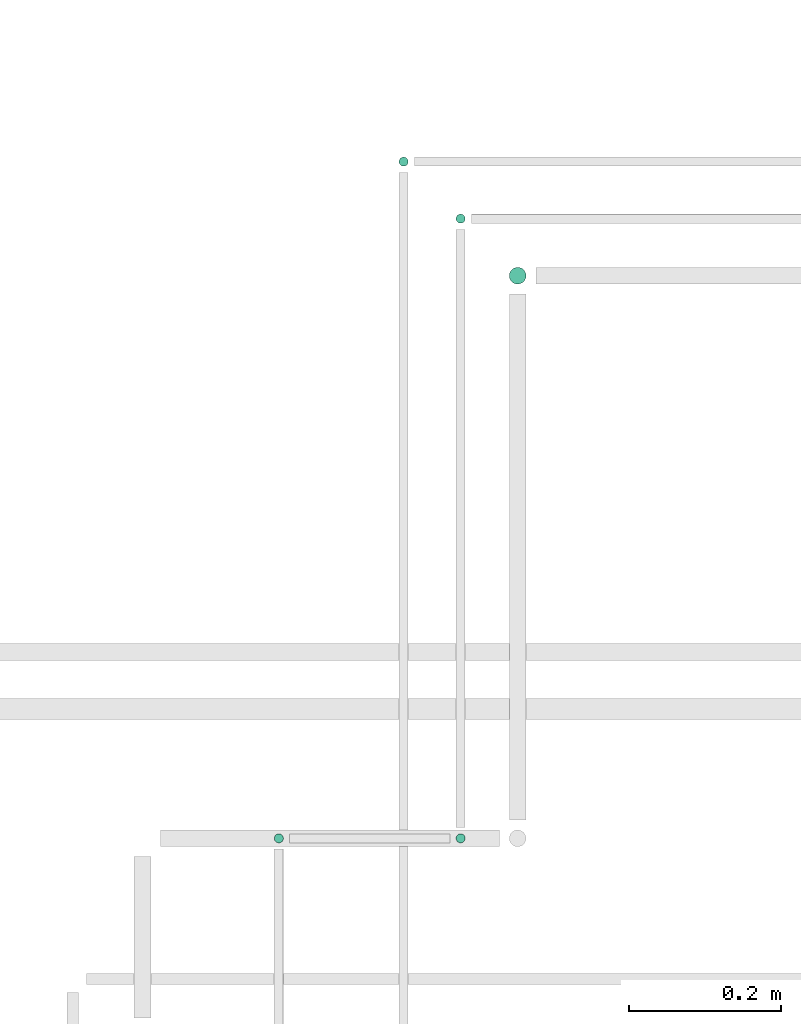
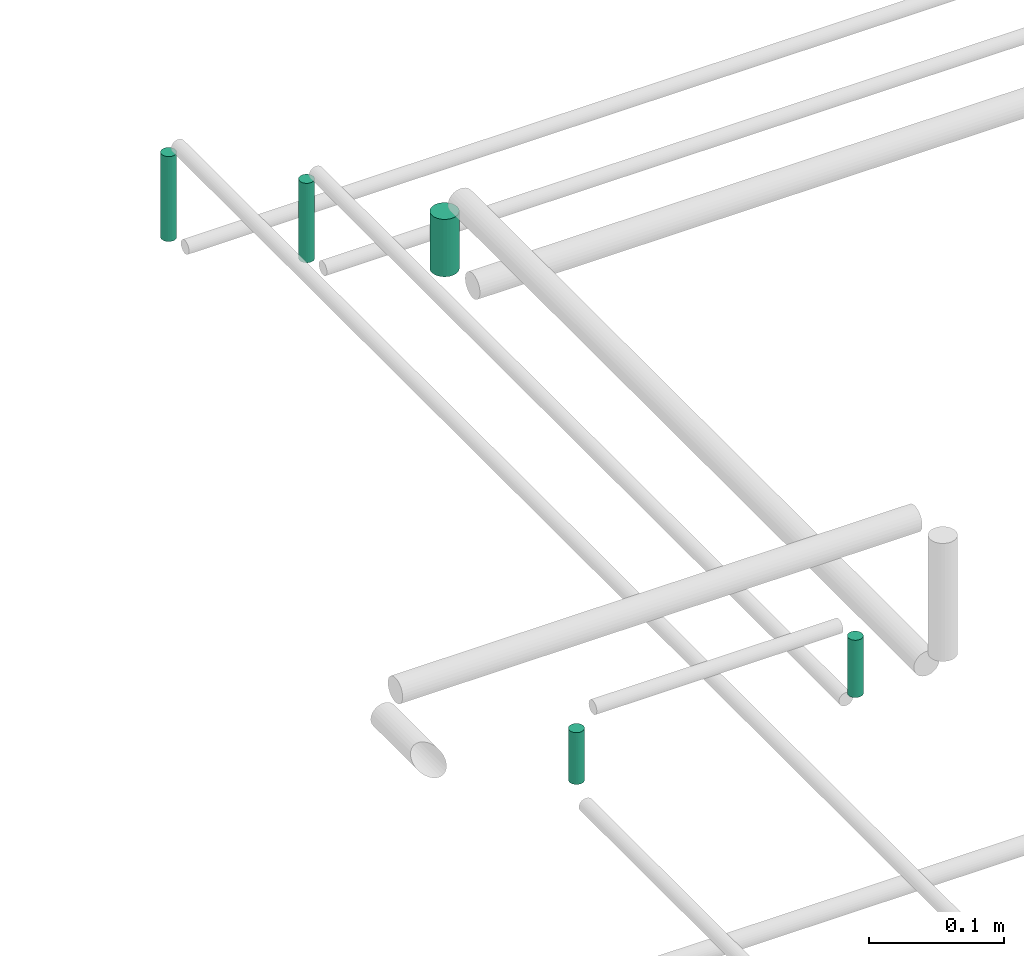
# One storey, part 251 of 331: 5 flow segments.
"""IFC2X3 building model written with IfcOpenShell, lengths in millimetres."""

from ifc_helpers import new_model, entity, si_unit, converted_unit, derived_unit, direction, frame, origin, origin_2d_with_axis, place, context, subcontext, project, spatial, circle, extrude, type_object, element, save


model = new_model("IFC2X3")

# Units and contexts
model_context = context("Model", 3, precision=0.01, world=origin(), true_north=direction((6.12303176911189e-17, 1.0)))
body_context = subcontext(model_context, "Body", "Model", "MODEL_VIEW")
ifc_project = project(units=[si_unit("LENGTHUNIT", "METRE", prefix="MILLI"), si_unit("AREAUNIT", "SQUARE_METRE"), si_unit("VOLUMEUNIT", "CUBIC_METRE"), converted_unit("PLANEANGLEUNIT", "DEGREE", entity("IfcRatioMeasure", 0.0174532925199433), si_unit("PLANEANGLEUNIT", "RADIAN"), dimensions=[0, 0, 0, 0, 0, 0, 0]), si_unit("MASSUNIT", "GRAM", prefix="KILO"), derived_unit("MASSDENSITYUNIT", [(si_unit("MASSUNIT", "GRAM", prefix="KILO"), 1), (si_unit("LENGTHUNIT", "METRE"), -3)]), derived_unit("MOMENTOFINERTIAUNIT", [(si_unit("LENGTHUNIT", "METRE"), 4)]), si_unit("TIMEUNIT", "SECOND"), si_unit("FREQUENCYUNIT", "HERTZ"), si_unit("THERMODYNAMICTEMPERATUREUNIT", "DEGREE_CELSIUS"), derived_unit("THERMALTRANSMITTANCEUNIT", [(si_unit("MASSUNIT", "GRAM", prefix="KILO"), 1), (si_unit("THERMODYNAMICTEMPERATUREUNIT", "KELVIN"), -1), (si_unit("TIMEUNIT", "SECOND"), -3)]), derived_unit("VOLUMETRICFLOWRATEUNIT", [(si_unit("LENGTHUNIT", "METRE"), 3), (si_unit("TIMEUNIT", "SECOND"), -1)]), derived_unit("MASSFLOWRATEUNIT", [(si_unit("MASSUNIT", "GRAM", prefix="KILO"), 1), (si_unit("TIMEUNIT", "SECOND"), -1)]), derived_unit("ROTATIONALFREQUENCYUNIT", [(si_unit("TIMEUNIT", "SECOND"), -1)]), si_unit("ELECTRICCURRENTUNIT", "AMPERE"), si_unit("ELECTRICVOLTAGEUNIT", "VOLT"), si_unit("POWERUNIT", "WATT"), si_unit("FORCEUNIT", "NEWTON", prefix="KILO"), si_unit("ILLUMINANCEUNIT", "LUX"), si_unit("LUMINOUSFLUXUNIT", "LUMEN"), si_unit("LUMINOUSINTENSITYUNIT", "CANDELA"), derived_unit("USERDEFINED", [(si_unit("MASSUNIT", "GRAM", prefix="KILO"), -1), (si_unit("LENGTHUNIT", "METRE"), -2), (si_unit("TIMEUNIT", "SECOND"), 3), (si_unit("LUMINOUSFLUXUNIT", "LUMEN"), 1)]), derived_unit("LINEARVELOCITYUNIT", [(si_unit("LENGTHUNIT", "METRE"), 1), (si_unit("TIMEUNIT", "SECOND"), -1)]), si_unit("PRESSUREUNIT", "PASCAL"), derived_unit("USERDEFINED", [(si_unit("LENGTHUNIT", "METRE"), -2), (si_unit("MASSUNIT", "GRAM", prefix="KILO"), 1), (si_unit("TIMEUNIT", "SECOND"), -2)]), derived_unit("LINEARFORCEUNIT", [(si_unit("MASSUNIT", "GRAM", prefix="KILO"), 1), (si_unit("LENGTHUNIT", "METRE"), 1), (si_unit("TIMEUNIT", "SECOND"), -2), (si_unit("LENGTHUNIT", "METRE"), -1)]), derived_unit("PLANARFORCEUNIT", [(si_unit("MASSUNIT", "GRAM", prefix="KILO"), 1), (si_unit("LENGTHUNIT", "METRE"), 1), (si_unit("TIMEUNIT", "SECOND"), -2), (si_unit("LENGTHUNIT", "METRE"), -2)])], contexts=[model_context])

# Site, building, storey
site_placement = place(None, frame((0.0, -0.00077364408347762, 0.0)))
site = spatial("IfcSite", under=ifc_project, at=site_placement, CompositionType="ELEMENT")
building_placement = place(site_placement, origin())
building = spatial("IfcBuilding", under=site, at=building_placement, CompositionType="ELEMENT")
storey_placement = place(building_placement, origin())
storey = spatial("IfcBuildingStorey", under=building, at=storey_placement, CompositionType="ELEMENT", Elevation=0.0)

# Flow segments
pipe_segment_type = type_object("IfcPipeSegmentType", PredefinedType="NOTDEFINED")
flow_segment_1_placement = place(storey_placement, frame((18988.4518462125, 10342.430236278, 18464.0)))
element("IfcFlowSegment", 1, at=flow_segment_1_placement, inside=storey, type_object=pipe_segment_type, context=body_context, shape_type="SweptSolid", body=[
    extrude(circle(Radius=6.0, at=origin_2d_with_axis()), frame((7.5952722359167, 7.5952722359167, 0.0)), (0.0, 0.0, 1.0), 76.9999999999219),
])
flow_segment_2_placement = place(storey_placement, frame((18824.2932984618, 9452.40472776839, 18569.0)))
element("IfcFlowSegment", 2, at=flow_segment_2_placement, inside=storey, type_object=pipe_segment_type, context=body_context, shape_type="SweptSolid", body=[
    extrude(circle(Radius=6.0, at=origin_2d_with_axis()), frame((7.5952722359167, 7.59527223591562, 0.0)), (0.0, 0.0, 1.0), 47.0000000000326),
])
flow_segment_3_placement = place(building_placement, frame((19063.4518462125, 9452.4047277684, 18564.0)))
element("IfcFlowSegment", 3, at=flow_segment_3_placement, inside=storey, type_object=pipe_segment_type, context=body_context, shape_type="SweptSolid", body=[
    extrude(circle(Radius=6.0, at=origin_2d_with_axis()), frame((7.5952722359167, 7.59527223591562, 0.0)), (0.0, 0.0, 1.0), 51.9999999999579),
])
flow_segment_4_placement = place(building_placement, frame((19063.4518462125, 10267.430236278, 18464.0)))
element("IfcFlowSegment", 4, at=flow_segment_4_placement, inside=storey, type_object=pipe_segment_type, context=body_context, shape_type="SweptSolid", body=[
    extrude(circle(Radius=6.0, at=origin_2d_with_axis()), frame((7.5952722359167, 7.5952722359167, 0.0), z_axis=(0.0, 0.0, 1.0), x_axis=(-1.0, 0.0, 0.0)), (0.0, 0.0, 1.0), 72.0000000000356),
])
flow_segment_5_placement = place(building_placement, frame((19133.4518462125, 10187.430236278, 18474.0)))
element("IfcFlowSegment", 5, at=flow_segment_5_placement, inside=storey, type_object=pipe_segment_type, context=body_context, shape_type="SweptSolid", body=[
    extrude(circle(Radius=11.0, at=origin_2d_with_axis()), frame((12.5952722359156, 12.5952722359156, 0.0), z_axis=(0.0, 0.0, 1.0), x_axis=(-1.0, 0.0, 0.0)), (0.0, 0.0, 1.0), 52.000000000038),
])

save(model, "model.ifc")
